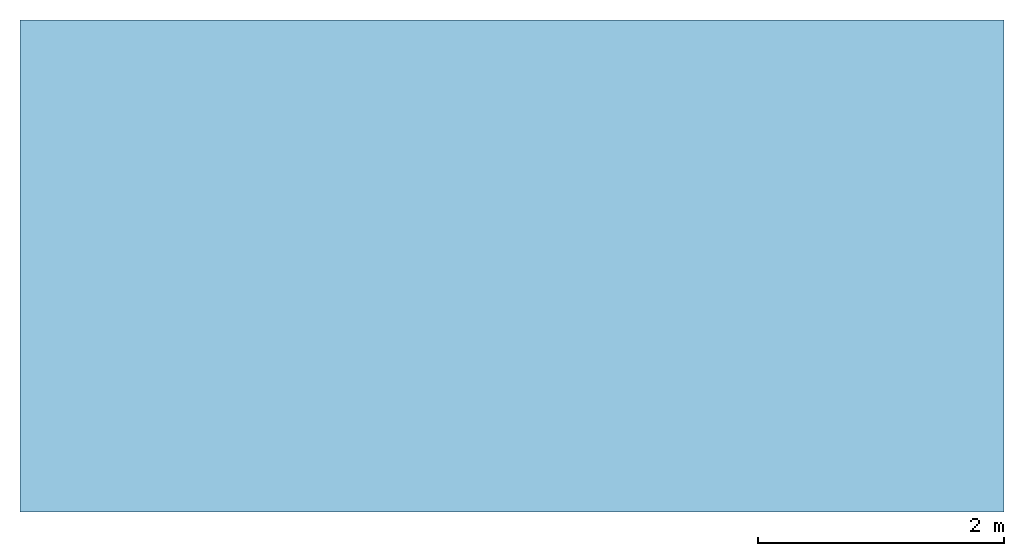
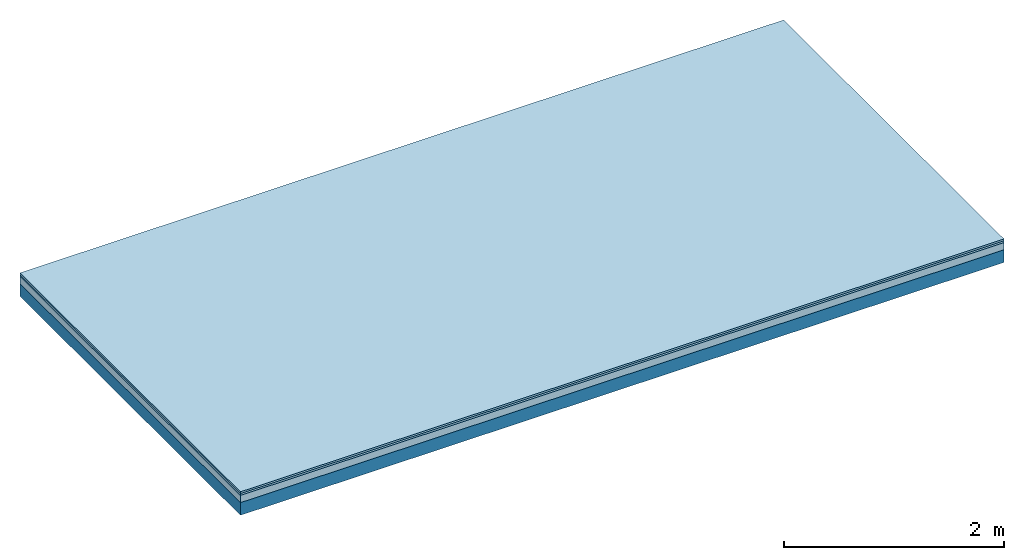
# One storey: 3 plates, 1 member, 1 element without a shape of its own.
"""IFC4 building model written with IfcOpenShell, lengths in metres."""

from ifc_helpers import new_model, si_unit, derived_unit, direction, frame, frame_2d, origin, origin_with_axes, place, context, project, spatial, rectangle, extrude, material, layer, layer_set, type_object, element, aggregate, save


model = new_model("IFC4")

# Units and contexts
plan_context = context("Plan", 3, precision=1e-05, world=origin(), true_north=direction((0.0, 1.0)))
model_context = context("Model", 3, precision=1e-05, world=origin(), true_north=direction((0.0, 1.0)))
ifc_project = project(units=[si_unit("LENGTHUNIT", "METRE"), derived_unit("SOUNDPRESSUREUNIT", [(si_unit("PRESSUREUNIT", "PASCAL", prefix="MICRO"), 0)]), si_unit("ENERGYUNIT", "JOULE", prefix="MEGA"), si_unit("MASSUNIT", "GRAM", prefix="KILO"), derived_unit("THERMALTRANSMITTANCEUNIT", [(si_unit("POWERUNIT", "WATT"), 1), (si_unit("AREAUNIT", "SQUARE_METRE"), -1), (si_unit("THERMODYNAMICTEMPERATUREUNIT", "KELVIN"), -1)]), derived_unit("AREADENSITYUNIT", [(si_unit("MASSUNIT", "GRAM", prefix="KILO"), 1), (si_unit("AREAUNIT", "SQUARE_METRE"), -1)]), derived_unit("USERDEFINED", [(si_unit("ENERGYUNIT", "JOULE", prefix="MEGA"), 1), (si_unit("AREAUNIT", "SQUARE_METRE"), -1)])], contexts=[plan_context, model_context])

# Site, building, storey
site = spatial("IfcSite", under=ifc_project)
building_placement = place(None, origin())
building = spatial("IfcBuilding", under=site, at=building_placement)
storey_placement = place(building_placement, origin())
storey = spatial("IfcBuildingStorey", under=building, at=storey_placement)

# Slab, member, plates
ifc_material_1 = material(Name="Phone Twin Star", Category="03.013")
ifc_layer_1 = layer(ifc_material_1, 0.02, Name="On-material")
ifc_material_2 = material(Name="EP3")
ifc_layer_2 = layer(ifc_material_2, 0.02, Name="Impact sound insulation")
ifc_material_3 = material(Category="03.011")
ifc_layer_3 = layer(ifc_material_3, 0.08, Name="on Supporting structure")
ifc_material_4 = material(Name="no composite action")
ifc_layer_4 = layer(ifc_material_4, 0.0, Name="Bond")
ifc_layer_5 = layer(None, 0.14, Name="Supporting structure")
ifc_layer_set = layer_set([ifc_layer_1, ifc_layer_2, ifc_layer_3, ifc_layer_4, ifc_layer_5])
slab_type = type_object("IfcSlabType", Name="A2442", PredefinedType="NOTDEFINED", material=ifc_layer_set)
slab_placement = place(None, frame((0.0, 0.0, 0.0), z_axis=(0.0, 0.0, -1.0), x_axis=(1.0, 0.0, 0.0)))
slab = element("IfcSlab", 1, at=slab_placement, inside=storey, type_object=slab_type, material=ifc_layer_set, Name="Slab #1")
ifc_material_5 = material()
member_placement = place(slab_placement, origin())
member = element("IfcMember", 2, at=member_placement, material=ifc_material_5, Name="Supporting structure", context=plan_context, shape_type="SweptSolid", body=[
    extrude(rectangle(XDim=1.0, YDim=0.14, at=frame_2d((0.5, 0.07), x_axis=(1.0, 0.0))), frame((0.0, 4.0, 0.12), z_axis=(0.0, -1.0, 0.0), x_axis=(1.0, 0.0, 0.0)), (0.0, 0.0, 1.0), 4.0),
    extrude(rectangle(XDim=1.0, YDim=0.14, at=frame_2d((0.5, 0.07), x_axis=(1.0, 0.0))), frame((1.0, 4.0, 0.12), z_axis=(0.0, -1.0, 0.0), x_axis=(1.0, 0.0, 0.0)), (0.0, 0.0, 1.0), 4.0),
    extrude(rectangle(XDim=1.0, YDim=0.14, at=frame_2d((0.5, 0.07), x_axis=(1.0, 0.0))), frame((2.0, 4.0, 0.12), z_axis=(0.0, -1.0, 0.0), x_axis=(1.0, 0.0, 0.0)), (0.0, 0.0, 1.0), 4.0),
    extrude(rectangle(XDim=1.0, YDim=0.14, at=frame_2d((0.5, 0.07), x_axis=(1.0, 0.0))), frame((3.0, 4.0, 0.12), z_axis=(0.0, -1.0, 0.0), x_axis=(1.0, 0.0, 0.0)), (0.0, 0.0, 1.0), 4.0),
    extrude(rectangle(XDim=1.0, YDim=0.14, at=frame_2d((0.5, 0.07), x_axis=(1.0, 0.0))), frame((4.0, 4.0, 0.12), z_axis=(0.0, -1.0, 0.0), x_axis=(1.0, 0.0, 0.0)), (0.0, 0.0, 1.0), 4.0),
    extrude(rectangle(XDim=1.0, YDim=0.14, at=frame_2d((0.5, 0.07), x_axis=(1.0, 0.0))), frame((5.0, 4.0, 0.12), z_axis=(0.0, -1.0, 0.0), x_axis=(1.0, 0.0, 0.0)), (0.0, 0.0, 1.0), 4.0),
    extrude(rectangle(XDim=1.0, YDim=0.14, at=frame_2d((0.5, 0.07), x_axis=(1.0, 0.0))), frame((6.0, 4.0, 0.12), z_axis=(0.0, -1.0, 0.0), x_axis=(1.0, 0.0, 0.0)), (0.0, 0.0, 1.0), 4.0),
    extrude(rectangle(XDim=1.0, YDim=0.14, at=frame_2d((0.5, 0.07), x_axis=(1.0, 0.0))), frame((7.0, 4.0, 0.12), z_axis=(0.0, -1.0, 0.0), x_axis=(1.0, 0.0, 0.0)), (0.0, 0.0, 1.0), 4.0),
])
plate_1_placement = place(slab_placement, origin())
plate_1 = element("IfcPlate", 3, at=plate_1_placement, material=ifc_material_1, Name="On-material", context=plan_context, shape_type="SweptSolid", body=[
    extrude(rectangle(XDim=8.0, YDim=4.0, at=frame_2d((4.0, 2.0), x_axis=(1.0, 0.0))), origin_with_axes(), (0.0, 0.0, 1.0), 0.02),
])
plate_2_placement = place(slab_placement, origin())
plate_2 = element("IfcPlate", 4, at=plate_2_placement, material=ifc_material_2, Name="Impact sound insulation", context=plan_context, shape_type="SweptSolid", body=[
    extrude(rectangle(XDim=8.0, YDim=4.0, at=frame_2d((4.0, 2.0), x_axis=(1.0, 0.0))), frame((0.0, 0.0, 0.02), z_axis=(0.0, 0.0, 1.0), x_axis=(1.0, 0.0, 0.0)), (0.0, 0.0, 1.0), 0.02),
])
plate_3_placement = place(slab_placement, origin())
plate_3 = element("IfcPlate", 5, at=plate_3_placement, material=ifc_material_3, Name="on Supporting structure", context=plan_context, shape_type="SweptSolid", body=[
    extrude(rectangle(XDim=8.0, YDim=4.0, at=frame_2d((4.0, 2.0), x_axis=(1.0, 0.0))), frame((0.0, 0.0, 0.04), z_axis=(0.0, 0.0, 1.0), x_axis=(1.0, 0.0, 0.0)), (0.0, 0.0, 1.0), 0.08),
])
aggregate(slab, [plate_1, plate_2, plate_3, member])

save(model, "model.ifc")
